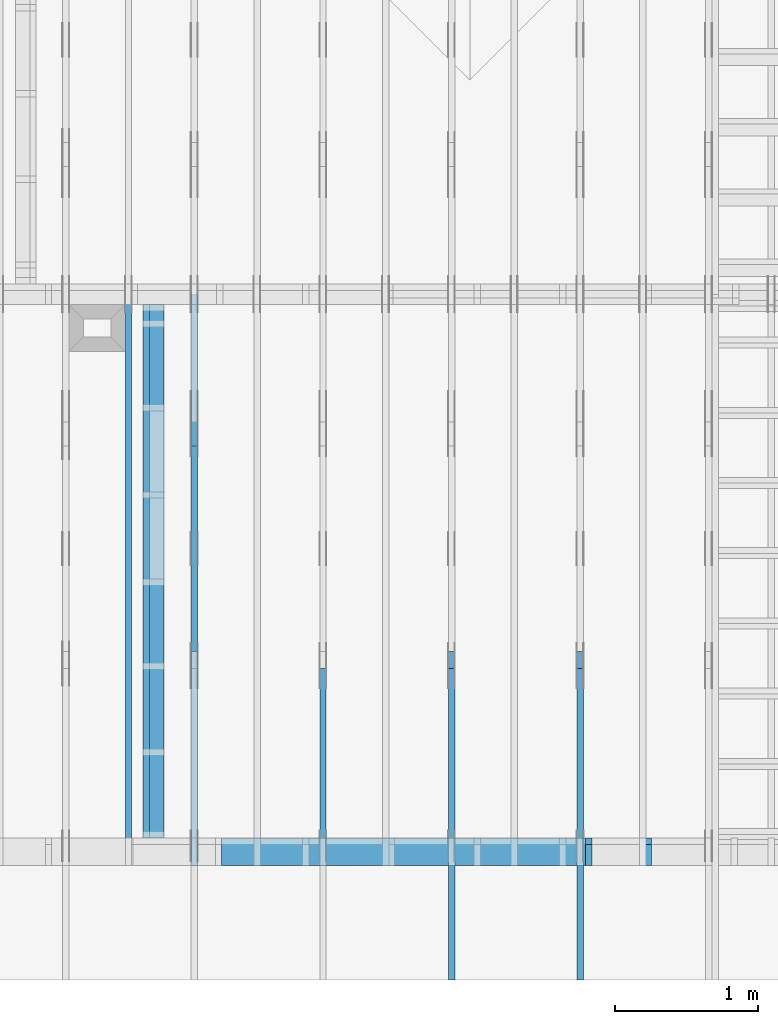
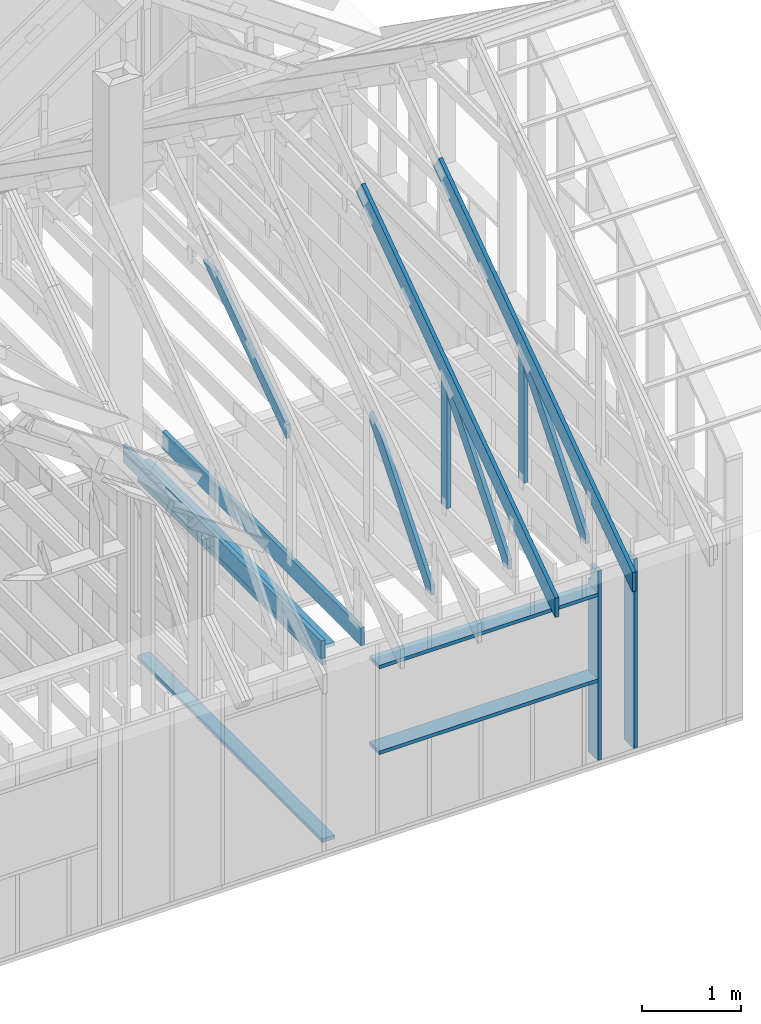
# One storey, part 20 of 70: 17 members, 7 elements without a shape of their own.
"""IFC2X3 building model written with IfcOpenShell, lengths in millimetres."""

from ifc_helpers import new_model, si_unit, frame, origin, origin_with_axes, origin_2d, place, context, project, spatial, faceted_brep, element, aggregate, save


model = new_model("IFC2X3")

# Units and contexts
model_context = context("Model", 3, precision=1e-05, world=origin())
plan_context = context("Plan", 2, precision=1e-05, world=origin_2d())
ifc_project = project(units=[si_unit("LENGTHUNIT", "METRE", prefix="MILLI"), si_unit("AREAUNIT", "SQUARE_METRE"), si_unit("VOLUMEUNIT", "CUBIC_METRE"), si_unit("SOLIDANGLEUNIT", "STERADIAN"), si_unit("PLANEANGLEUNIT", "RADIAN"), si_unit("MASSUNIT", "GRAM"), si_unit("TIMEUNIT", "SECOND"), si_unit("THERMODYNAMICTEMPERATUREUNIT", "DEGREE_CELSIUS"), si_unit("LUMINOUSINTENSITYUNIT", "LUMEN")], contexts=[model_context, plan_context])

# Site, building, storey
site_placement = place(None, origin_with_axes())
site = spatial("IfcSite", under=ifc_project, at=site_placement, CompositionType="ELEMENT")
building_placement = place(site_placement, origin_with_axes())
building = spatial("IfcBuilding", under=site, at=building_placement, Name="Layout 1", CompositionType="ELEMENT")
storey_placement = place(building_placement, origin_with_axes())
storey = spatial("IfcBuildingStorey", under=building, at=storey_placement, Name="Storey 1", CompositionType="ELEMENT", Elevation=0.0)

# Assembly, members
assembly_1_placement = place(storey_placement, frame((-48.55339059325575, 0.0, -2470.0), z_axis=(0.0, -1.0, 6.123031769111886e-17), x_axis=(1.0, 0.0, 0.0)))
assembly_1 = element("IfcElementAssembly", 1, at=assembly_1_placement, inside=storey, Name="VE4", AssemblyPlace="FACTORY", PredefinedType="NOTDEFINED")
member_1_placement = place(assembly_1_placement, frame((10777.499999992955, 2425.0, -195.00000000000003), z_axis=(0.0, 0.0, 1.0), x_axis=(7.044874666267686e-16, -1.0, 0.0)))
member_1 = element("IfcMember", 2, at=member_1_placement, Name="S11", context=model_context, shape_type="Brep", body=[
    faceted_brep([(0.0, 45.00000000000182, 45.00000000000003), (195.00000000186265, 45.00000000000182, 45.00000000000005), (195.00000000186265, 1.8189894035458565e-12, 45.00000000000005), (0.0, 1.8189894035458565e-12, 45.00000000000003), (195.00000000186265, 1.8189894035458565e-12, 2.842170943040401e-14), (195.00000000186265, 1.8189894035458565e-12, 45.00000000000003), (195.00000000186265, 45.00000000000182, 45.00000000000003), (195.00000000186265, 45.00000000000182, 2.842170943040401e-14), (2.7553642961005733e-15, 1.8189894035458565e-12, 45.00000000000003), (1.1939911949768402e-14, 1.8189894035458565e-12, 195.00000000000003), (1.74506405419691e-14, 45.00000000000182, 195.00000000000003), (8.26609288830127e-15, 45.00000000000182, 45.00000000000003), (2335.0, 1.3900710281195688e-12, 2.842170943040403e-14), (2335.0, 1.402010940069337e-12, 195.00000000000003), (2.1932538056648764e-30, 1.8309293154956247e-12, 195.00000000000003), (5.061354936149717e-31, 1.821744767841957e-12, 45.00000000000003), (195.00000000186265, 1.7859250319923102e-12, 45.00000000000003), (195.00000000186265, 1.7831696676962098e-12, 2.842170943040401e-14), (-1.6871183120499057e-31, 45.00000000000182, 45.00000000000003), (-7.310846018882921e-31, 45.000000000001805, 195.00000000000003), (2335.0, 45.00000000000166, 195.00000000000003), (2335.0, 45.00000000000168, 2.8421709430403998e-14), (195.00000000186265, 45.000000000001805, 2.8421709430404004e-14), (195.00000000186265, 45.000000000001805, 45.00000000000003), (2335.0, 45.0, 0.0), (2335.0, 45.0, 195.00000000000003), (2335.0, 0.0, 195.00000000000003), (2335.0, 0.0, 0.0), (2335.0, 45.0, 195.00000000000003), (0.0, 45.0, 195.00000000000003), (0.0, 1.8189894035458565e-12, 195.00000000000003), (2335.0, 1.8189894035458565e-12, 195.00000000000003), (195.00000000186265, 45.00000000000182, 5.2301533330168465e-14), (2335.0, 45.00000000000182, 3.143672930479291e-13), (2335.0, 0.0, 3.143672930479291e-13), (195.00000000186265, 0.0, 5.2301533330168465e-14)], [[[0, 1, 2, 3]], [[4, 5, 6, 7]], [[8, 9, 10, 11]], [[12, 13, 14, 15, 16, 17]], [[18, 19, 20, 21, 22, 23]], [[24, 25, 26, 27]], [[28, 29, 30, 31]], [[32, 33, 34, 35]]]),
])
member_2_placement = place(assembly_1_placement, frame((10358.553390595087, 2425.0, -195.00000000000003), z_axis=(0.0, 0.0, 1.0), x_axis=(-1.836909530733566e-16, -1.0, 0.0)))
member_2 = element("IfcMember", 3, at=member_2_placement, Name="S11", context=model_context, shape_type="Brep", body=[
    faceted_brep([(0.0, 45.00000000001455, 45.00000000000003), (195.00000000186265, 45.00000000001455, 45.00000000000005), (195.00000000186265, 0.0, 45.00000000000005), (0.0, 0.0, 45.00000000000003), (195.00000000186265, -2.1311460639909362e-46, 2.842170943040401e-14), (195.00000000186265, -3.3742366240998114e-31, 45.00000000000003), (195.00000000186265, 45.00000000001273, 45.00000000000003), (195.00000000186265, 45.00000000001273, 2.842170943040401e-14), (2.7553642961003504e-15, -3.3742366240998114e-31, 45.00000000000003), (1.1939911949768181e-14, -1.4621692037765844e-30, 195.00000000000006), (1.7450640541970662e-14, 45.00000000001455, 195.00000000000006), (8.26609288830283e-15, 45.00000000001455, 45.00000000000003), (2335.0, -4.2891837542628763e-13, 2.842170943040403e-14), (2335.0, -4.1697846347651946e-13, 195.00000000000003), (2.1932538056648764e-30, 1.193991194976818e-14, 195.00000000000003), (5.061354936149717e-31, 2.7553642961003504e-15, 45.00000000000003), (195.00000000186265, -3.306437155354634e-14, 45.00000000000003), (195.00000000186265, -3.5819735849646686e-14, 2.842170943040401e-14), (-1.6871183120499057e-31, 45.00000000001273, 45.00000000000003), (-7.310846018882921e-31, 45.00000000001272, 195.00000000000003), (2335.0, 45.00000000001258, 195.00000000000003), (2335.0, 45.00000000001259, 2.8421709430403998e-14), (195.00000000186265, 45.00000000001272, 2.842170943040401e-14), (195.00000000186265, 45.00000000001272, 45.00000000000003), (2335.0, 45.0, 0.0), (2335.0, 45.0, 195.00000000000003), (2335.0, 0.0, 195.00000000000003), (2335.0, 0.0, 0.0), (2335.0, 45.0, 195.00000000000003), (0.0, 45.0, 195.00000000000003), (0.0, 0.0, 195.00000000000003), (2335.0, 0.0, 195.00000000000003), (195.00000000186265, 45.00000000001273, 5.2301533330168465e-14), (2335.0, 45.00000000001273, 3.143672930479291e-13), (2335.0, 0.0, 3.143672930479291e-13), (195.00000000186265, 0.0, 5.2301533330168465e-14)], [[[0, 1, 2, 3]], [[4, 5, 6, 7]], [[8, 9, 10, 11]], [[12, 13, 14, 15, 16, 17]], [[18, 19, 20, 21, 22, 23]], [[24, 25, 26, 27]], [[28, 29, 30, 31]], [[32, 33, 34, 35]]]),
])
member_3_placement = place(assembly_1_placement, frame((10358.553390593253, 2154.9999999987776, -195.0), z_axis=(0.0, 0.0, 1.0), x_axis=(-1.0, 1.2246063538223773e-16, 0.0)))
member_3 = element("IfcMember", 4, at=member_3_placement, Name="S10", context=model_context, shape_type="Brep", body=[
    faceted_brep([(2546.0533905914344, 45.00000000001501, 195.0), (0.0, 45.00000000001501, 195.0), (0.0, 0.0, 195.0), (2546.0533905914344, 0.0, 195.0), (0.0, 45.00000000001501, 0.0), (2546.0533905914344, 45.00000000001501, 3.1179131592892776e-13), (2546.0533905914344, 0.0, 3.1179131592892776e-13), (0.0, 0.0, 0.0), (0.0, 0.0, 0.0), (1.1939911949768178e-14, -1.462169203776584e-30, 195.0), (1.745064054197066e-14, 45.00000000001455, 195.0), (5.51072859220248e-15, 45.00000000001455, -3.3742366241009005e-31), (2546.0533905914344, -4.676869738933916e-13, 5.648094675546328e-29), (2546.0533905914344, -4.557470619436235e-13, 195.0), (2.193253805664876e-30, 1.1939911949768178e-14, 195.0), (0.0, 0.0, 0.0), (2546.0533905914344, 45.00000000001501, 0.0), (2546.0533905914344, 45.00000000001501, 195.0), (2546.0533905914344, 4.547473508864641e-13, 195.0), (2546.0533905914344, 4.547473508864641e-13, 0.0), (0.0, 45.00000000001455, 0.0), (1.5777218104420236e-30, 45.00000000001454, 195.0), (2546.0533905914344, 45.00000000001495, 195.0), (2546.0533905914344, 45.000000000014964, -2.7610131682735413e-30)], [[[0, 1, 2, 3]], [[4, 5, 6, 7]], [[8, 9, 10, 11]], [[12, 13, 14, 15]], [[16, 17, 18, 19]], [[20, 21, 22, 23]]]),
])
member_4_placement = place(assembly_1_placement, frame((7812.500000001819, 1055.0, -195.0), z_axis=(0.0, 0.0, 1.0), x_axis=(1.0, 0.0, 0.0)))
member_4 = element("IfcMember", 5, at=member_4_placement, Name="S10", context=model_context, shape_type="Brep", body=[
    faceted_brep([(2546.0533905914344, 45.0, 195.0), (0.0, 45.0, 195.0), (0.0, 0.0, 195.0), (2546.0533905914344, 0.0, 195.0), (0.0, 45.0, 0.0), (2546.0533905914344, 45.0, 3.1179131592892776e-13), (2546.0533905914344, 0.0, 3.1179131592892776e-13), (0.0, 0.0, 0.0), (0.0, 0.0, 0.0), (1.1939911949768178e-14, -1.462169203776584e-30, 195.0), (1.7450640541968876e-14, 45.0, 195.0), (5.510728592200698e-15, 45.0, -3.3742366240998092e-31), (2546.0533905914344, -4.676869738933916e-13, 2.8636621991490384e-29), (2546.0533905914344, -4.557470619436235e-13, 195.0), (2.193253805664876e-30, 1.1939911949768178e-14, 195.0), (0.0, 0.0, 0.0), (2546.0533905914344, 45.0, 0.0), (2546.0533905914344, 45.0, 195.0), (2546.0533905914344, 0.0, 195.0), (2546.0533905914344, 0.0, 0.0), (0.0, 45.0, 0.0), (-7.31084601888292e-31, 44.999999999999986, 195.0), (2546.0533905914344, 44.99999999999983, 195.0), (2546.0533905914344, 44.999999999999844, -9.466330862652142e-30)], [[[0, 1, 2, 3]], [[4, 5, 6, 7]], [[8, 9, 10, 11]], [[12, 13, 14, 15]], [[16, 17, 18, 19]], [[20, 21, 22, 23]]]),
])
aggregate(assembly_1, [member_1, member_2, member_3, member_4])

# Assembly, member
assembly_2_placement = place(storey_placement, frame((7088.750000000147, 8000.0, 1.3776821480501744e-15), z_axis=(-1.0, 1.836909530733566e-16, 6.123031769111886e-17), x_axis=(-1.836909530733566e-16, -1.0, 0.0)))
assembly_2 = element("IfcElementAssembly", 6, at=assembly_2_placement, inside=storey, Name="MB1", AssemblyPlace="FACTORY", PredefinedType="TRUSS")
member_5_placement = place(assembly_2_placement, frame((8000.000000000001, 220.0, -45.0), z_axis=(0.0, 0.0, 1.0), x_axis=(-1.0, 1.2246063538223773e-16, 0.0)))
member_5 = element("IfcMember", 7, at=member_5_placement, Name="B3", context=model_context, shape_type="Brep", body=[
    faceted_brep([(4000.0000000000005, 220.0000000000005, 45.0), (0.0, 220.0000000000005, 45.0), (0.0, 0.0, 45.0), (4000.0000000000005, 0.0, 45.0), (0.0, 220.0000000000005, 0.0), (4000.0000000000005, 220.0000000000005, 4.89842541528951e-13), (4000.0000000000005, 0.0, 4.89842541528951e-13), (0.0, 0.0, 0.0), (0.0, 0.0, 0.0), (2.755364296100349e-15, -3.3742366240998092e-31, 45.0), (2.969670408019265e-14, 220.0, 45.0), (2.69413397840923e-14, 220.0, -1.6496267940043512e-30), (4000.0000000000005, -7.347638122934265e-13, 7.631468701413364e-29), (4000.0000000000005, -7.320084479973261e-13, 45.0), (5.061354936149714e-31, 2.755364296100349e-15, 45.0), (0.0, 0.0, 0.0), (4000.0000000000005, 220.0000000000005, 0.0), (4000.0000000000005, 220.0000000000005, 45.0), (4000.0000000000005, 5.115907697472721e-13, 45.0), (4000.0000000000005, 5.115907697472721e-13, 0.0), (0.0, 220.0, 0.0), (0.0, 220.0, 45.0), (4000.0000000000005, 220.00000000000065, 45.0), (4000.0000000000005, 220.00000000000065, 7.888609052210118e-30)], [[[0, 1, 2, 3]], [[4, 5, 6, 7]], [[8, 9, 10, 11]], [[12, 13, 14, 15]], [[16, 17, 18, 19]], [[20, 21, 22, 23]]]),
])
aggregate(assembly_2, [member_5])

# Assembly, members
assembly_3_placement = place(storey_placement, frame((10250.0, 8000.0, -9.081170196248781e-13), z_axis=(-1.0, 1.836909530733566e-16, 6.123031769111886e-17), x_axis=(-1.836909530733566e-16, -1.0, 0.0)))
assembly_3 = element("IfcElementAssembly", 8, at=assembly_3_placement, inside=storey, Name="T3", AssemblyPlace="FACTORY", PredefinedType="TRUSS")
member_6_placement = place(assembly_3_placement, frame((4782.309641269037, 3015.0000000009313, -45.00000000000001), z_axis=(0.0, 0.0, 1.0), x_axis=(0.8191520442889916, -0.5735764363510465, 0.0)))
member_6 = element("IfcMember", 9, at=member_6_placement, Name="T8", context=model_context, shape_type="Brep", body=[
    faceted_brep([(4768.153825500145, 194.99999999946158, 45.0), (1.6370904631912708e-10, 194.99999999946158, 45.0), (0.0, 0.0, 45.0), (4904.694295450095, 0.0, 45.0), (1.6370904631912708e-10, 194.99999999946158, 2.004791383006049e-26), (4768.153825500145, 194.99999999946158, 5.839111470709952e-13), (4904.694295450095, 0.0, 6.006319797764554e-13), (0.0, 0.0, 0.0), (2.5849394142282115e-26, -2.1699301500556333e-38, -1.582766615454881e-42), (2.7553642961261982e-15, -2.3129934990511945e-27, 45.0), (1.6369571347777126e-10, 194.99999999920783, 45.0), (1.6369295811347516e-10, 194.99999999920783, 9.850859431479521e-31), (4904.694295450095, 8.093603669211209e-10, 5.505686690999094e-30), (4904.694295450095, 8.09363122285417e-10, 45.0), (-4.546833142611764e-28, 2.755364296100349e-15, 45.0), (0.0, 0.0, 0.0), (4768.153825500146, 194.99999999946203, 5.048709793414476e-29), (4768.153825500146, 194.99999999946203, 45.0), (4904.6942954500955, 8.094502845779061e-10, 45.0), (4904.6942954500955, 8.094502845779061e-10, 5.048709793414476e-29), (1.6370904631912708e-10, 194.99999999920783, 0.0), (1.6370904631912708e-10, 194.99999999920783, 45.0), (4768.153825500145, 194.99999999946164, 45.0), (4768.153825500145, 194.99999999946164, 3.1554436208840472e-30)], [[[0, 1, 2, 3]], [[4, 5, 6, 7]], [[8, 9, 10, 11]], [[12, 13, 14, 15]], [[16, 17, 18, 19]], [[20, 21, 22, 23]]]),
])
member_7_placement = place(assembly_3_placement, frame((6619.999999999389, 220.0, -45.0), z_axis=(0.0, 0.0, 1.0), x_axis=(6.123031769111886e-17, 1.0, 0.0)))
member_7 = element("IfcMember", 10, at=member_7_placement, Name="R1", context=model_context, shape_type="Brep", body=[
    faceted_brep([(1592.2602625068248, 120.0, 45.0), (0.0, 120.0, 45.0), (0.0, 1.4551915228366852e-11, 45.0), (1508.235357921585, 1.4551915228366852e-11, 45.0), (0.0, 120.0, 0.0), (1592.2602625068248, 120.0, 1.949892034404744e-13), (1508.235357921585, 1.4551915228366852e-11, 1.8469946023703405e-13), (0.0, 1.4551915228366852e-11, 0.0), (1.7820367848942657e-27, 1.4551915228366852e-11, -1.0911467847633593e-43), (2.755364296102131e-15, 1.4551915228366852e-11, 45.0), (1.7450640541968876e-14, 120.0, 45.0), (1.4695276245868527e-14, 120.0, -8.997964330932825e-31), (1508.235357921585, -4.605370260698061e-13, 2.81988284147774e-29), (1508.235357921585, -4.577816617737058e-13, 45.0), (2.7425941661909085e-29, 1.4554670592662952e-11, 45.0), (0.0, 1.4551915228366852e-11, 0.0), (1592.260262506825, 120.00000000000011, 1.262177448353619e-29), (1592.260262506825, 120.00000000000011, 45.0), (1508.2353579215853, 0.0, 45.0), (1508.2353579215853, 0.0, 1.262177448353619e-29), (0.0, 120.0, 0.0), (-1.6871183120499046e-31, 120.0, 45.0), (1592.2602625068248, 119.9999999999999, 45.0), (1592.2602625068248, 119.9999999999999, -6.310887241768095e-30)], [[[0, 1, 2, 3]], [[4, 5, 6, 7]], [[8, 9, 10, 11]], [[12, 13, 14, 15]], [[16, 17, 18, 19]], [[20, 21, 22, 23]]]),
])
member_8_placement = place(assembly_3_placement, frame((6563.906131861293, 1682.303582892756, -45.0), z_axis=(0.0, 0.0, 1.0), x_axis=(0.6335417245359889, -0.7737085260432156, 0.0)))
member_8 = element("IfcMember", 11, at=member_8_placement, Name="W6", context=model_context, shape_type="Brep", body=[
    faceted_brep([(1860.8184531590368, 145.00000000000182, 45.0), (258.1329393113165, 145.00000000000182, 45.0), (0.0, 72.4999999999518, 45.0), (88.54013234752438, 0.0, 45.0), (1889.9928508879848, 0.0, 45.0), (1949.3585855061046, 72.4999999999518, 45.0), (258.1329393113165, 145.00000000000182, 3.161112376114843e-14), (1860.8184531590368, 145.00000000000182, 2.2787701010484843e-13), (1949.3585855061046, 72.4999999999518, 2.3871969096889775e-13), (1889.9928508879848, 0.0, 2.314497253876295e-13), (88.54013234752438, 0.0, 1.0842680864105255e-14), (0.0, 72.4999999999518, 0.0), (3.552713678800501e-15, 72.49999999995178, -7.284513455813184e-31), (3.552713678800501e-15, 72.49999999995178, 45.0), (258.13293931131653, 144.9999999999991, 45.0), (258.13293931131653, 144.9999999999991, 8.866211437223917e-31), (88.54013234752439, 0.0, 8.758115402030107e-47), (88.54013234752439, 0.0, 45.0), (0.0, 72.49999999995181, 45.0), (0.0, 72.4999999999518, 8.758115402030107e-47), (1889.9928508879848, 1.2420742274003826e-12, 3.532469951621517e-29), (1889.9928508879848, 1.244829591696483e-12, 45.0), (88.54013234752438, -2.4271270235991317e-14, 45.0), (88.54013234752438, -2.7026634532091666e-14, 1.654849418521736e-30), (1949.3585855061053, 72.49999999999955, 6.310887241768094e-29), (1949.3585855061053, 72.49999999999955, 45.0), (1889.9928508879855, 1.3642420526593924e-12, 45.0), (1889.9928508879855, 1.3642420526593924e-12, 6.310887241768094e-29), (1860.8184531590368, 145.00000000000182, 0.0), (1860.8184531590368, 145.00000000000182, 45.0), (1949.3585855061046, 72.5, 45.0), (1949.3585855061046, 72.5, 0.0), (258.1329393113165, 144.99999999999912, 0.0), (258.1329393113165, 144.9999999999991, 45.0), (1860.8184531590368, 145.00000000000185, 45.0), (1860.8184531590368, 145.00000000000185, 1.5777218104420236e-30)], [[[0, 1, 2, 3, 4, 5]], [[6, 7, 8, 9, 10, 11]], [[12, 13, 14, 15]], [[16, 17, 18, 19]], [[20, 21, 22, 23]], [[24, 25, 26, 27]], [[28, 29, 30, 31]], [[32, 33, 34, 35]]]),
])
aggregate(assembly_3, [member_6, member_7, member_8])

assembly_4_placement = place(storey_placement, frame((9350.0, 8000.0, -9.081170196248781e-13), z_axis=(-1.0, 1.836909530733566e-16, 6.123031769111886e-17), x_axis=(-1.836909530733566e-16, -1.0, 0.0)))
assembly_4 = element("IfcElementAssembly", 12, at=assembly_4_placement, inside=storey, Name="T3", AssemblyPlace="FACTORY", PredefinedType="TRUSS")
member_9_placement = place(assembly_4_placement, frame((4782.309641269037, 3015.0000000009313, -45.00000000000001), z_axis=(0.0, 0.0, 1.0), x_axis=(0.8191520442889916, -0.5735764363510465, 0.0)))
member_9 = element("IfcMember", 13, at=member_9_placement, Name="T8", context=model_context, shape_type="Brep", body=[
    faceted_brep([(4768.153825500145, 194.99999999946158, 45.0), (1.6370904631912708e-10, 194.99999999946158, 45.0), (0.0, 0.0, 45.0), (4904.694295450095, 0.0, 45.0), (1.6370904631912708e-10, 194.99999999946158, 2.004791383006049e-26), (4768.153825500145, 194.99999999946158, 5.839111470709952e-13), (4904.694295450095, 0.0, 6.006319797764554e-13), (0.0, 0.0, 0.0), (2.5849394142282115e-26, -2.1699301500556333e-38, -1.582766615454881e-42), (2.7553642961261982e-15, -2.3129934990511945e-27, 45.0), (1.6369571347777126e-10, 194.99999999920783, 45.0), (1.6369295811347516e-10, 194.99999999920783, 9.850859431479521e-31), (4904.694295450095, 8.093603669211209e-10, 5.505686690999094e-30), (4904.694295450095, 8.09363122285417e-10, 45.0), (-4.546833142611764e-28, 2.755364296100349e-15, 45.0), (0.0, 0.0, 0.0), (4768.153825500146, 194.99999999946203, 5.048709793414476e-29), (4768.153825500146, 194.99999999946203, 45.0), (4904.6942954500955, 8.094502845779061e-10, 45.0), (4904.6942954500955, 8.094502845779061e-10, 5.048709793414476e-29), (1.6370904631912708e-10, 194.99999999920783, 0.0), (1.6370904631912708e-10, 194.99999999920783, 45.0), (4768.153825500145, 194.99999999946164, 45.0), (4768.153825500145, 194.99999999946164, 3.1554436208840472e-30)], [[[0, 1, 2, 3]], [[4, 5, 6, 7]], [[8, 9, 10, 11]], [[12, 13, 14, 15]], [[16, 17, 18, 19]], [[20, 21, 22, 23]]]),
])
member_10_placement = place(assembly_4_placement, frame((6619.999999999389, 220.0, -45.0), z_axis=(0.0, 0.0, 1.0), x_axis=(6.123031769111886e-17, 1.0, 0.0)))
member_10 = element("IfcMember", 14, at=member_10_placement, Name="R1", context=model_context, shape_type="Brep", body=[
    faceted_brep([(1592.2602625068248, 120.0, 45.0), (0.0, 120.0, 45.0), (0.0, 1.4551915228366852e-11, 45.0), (1508.235357921585, 1.4551915228366852e-11, 45.0), (0.0, 120.0, 0.0), (1592.2602625068248, 120.0, 1.949892034404744e-13), (1508.235357921585, 1.4551915228366852e-11, 1.8469946023703405e-13), (0.0, 1.4551915228366852e-11, 0.0), (1.7820367848942657e-27, 1.4551915228366852e-11, -1.0911467847633593e-43), (2.755364296102131e-15, 1.4551915228366852e-11, 45.0), (1.7450640541968876e-14, 120.0, 45.0), (1.4695276245868527e-14, 120.0, -8.997964330932825e-31), (1508.235357921585, -4.605370260698061e-13, 2.81988284147774e-29), (1508.235357921585, -4.577816617737058e-13, 45.0), (2.7425941661909085e-29, 1.4554670592662952e-11, 45.0), (0.0, 1.4551915228366852e-11, 0.0), (1592.260262506825, 120.00000000000011, 1.262177448353619e-29), (1592.260262506825, 120.00000000000011, 45.0), (1508.2353579215853, 0.0, 45.0), (1508.2353579215853, 0.0, 1.262177448353619e-29), (0.0, 120.0, 0.0), (-1.6871183120499046e-31, 120.0, 45.0), (1592.2602625068248, 119.9999999999999, 45.0), (1592.2602625068248, 119.9999999999999, -6.310887241768095e-30)], [[[0, 1, 2, 3]], [[4, 5, 6, 7]], [[8, 9, 10, 11]], [[12, 13, 14, 15]], [[16, 17, 18, 19]], [[20, 21, 22, 23]]]),
])
member_11_placement = place(assembly_4_placement, frame((6563.906131861293, 1682.303582892756, -45.0), z_axis=(0.0, 0.0, 1.0), x_axis=(0.6335417245359889, -0.7737085260432156, 0.0)))
member_11 = element("IfcMember", 15, at=member_11_placement, Name="W6", context=model_context, shape_type="Brep", body=[
    faceted_brep([(1860.8184531590368, 145.00000000000182, 45.0), (258.1329393113165, 145.00000000000182, 45.0), (0.0, 72.4999999999518, 45.0), (88.54013234752438, 0.0, 45.0), (1889.9928508879848, 0.0, 45.0), (1949.3585855061046, 72.4999999999518, 45.0), (258.1329393113165, 145.00000000000182, 3.161112376114843e-14), (1860.8184531590368, 145.00000000000182, 2.2787701010484843e-13), (1949.3585855061046, 72.4999999999518, 2.3871969096889775e-13), (1889.9928508879848, 0.0, 2.314497253876295e-13), (88.54013234752438, 0.0, 1.0842680864105255e-14), (0.0, 72.4999999999518, 0.0), (3.552713678800501e-15, 72.49999999995178, -7.284513455813184e-31), (3.552713678800501e-15, 72.49999999995178, 45.0), (258.13293931131653, 144.9999999999991, 45.0), (258.13293931131653, 144.9999999999991, 8.866211437223917e-31), (88.54013234752439, 0.0, 8.758115402030107e-47), (88.54013234752439, 0.0, 45.0), (0.0, 72.49999999995181, 45.0), (0.0, 72.4999999999518, 8.758115402030107e-47), (1889.9928508879848, 1.2420742274003826e-12, 3.532469951621517e-29), (1889.9928508879848, 1.244829591696483e-12, 45.0), (88.54013234752438, -2.4271270235991317e-14, 45.0), (88.54013234752438, -2.7026634532091666e-14, 1.654849418521736e-30), (1949.3585855061053, 72.49999999999955, 6.310887241768094e-29), (1949.3585855061053, 72.49999999999955, 45.0), (1889.9928508879855, 1.3642420526593924e-12, 45.0), (1889.9928508879855, 1.3642420526593924e-12, 6.310887241768094e-29), (1860.8184531590368, 145.00000000000182, 0.0), (1860.8184531590368, 145.00000000000182, 45.0), (1949.3585855061046, 72.5, 45.0), (1949.3585855061046, 72.5, 0.0), (258.1329393113165, 144.99999999999912, 0.0), (258.1329393113165, 144.9999999999991, 45.0), (1860.8184531590368, 145.00000000000185, 45.0), (1860.8184531590368, 145.00000000000185, 1.5777218104420236e-30)], [[[0, 1, 2, 3, 4, 5]], [[6, 7, 8, 9, 10, 11]], [[12, 13, 14, 15]], [[16, 17, 18, 19]], [[20, 21, 22, 23]], [[24, 25, 26, 27]], [[28, 29, 30, 31]], [[32, 33, 34, 35]]]),
])
aggregate(assembly_4, [member_9, member_10, member_11])

# Assembly, member
assembly_5_placement = place(storey_placement, frame((8450.0, 8000.0, -9.081170196248781e-13), z_axis=(-1.0, 1.836909530733566e-16, 6.123031769111886e-17), x_axis=(-1.836909530733566e-16, -1.0, 0.0)))
assembly_5 = element("IfcElementAssembly", 16, at=assembly_5_placement, inside=storey, Name="T3", AssemblyPlace="FACTORY", PredefinedType="TRUSS")
member_12_placement = place(assembly_5_placement, frame((6563.906131861293, 1682.303582892756, -45.0), z_axis=(0.0, 0.0, 1.0), x_axis=(0.6335417245359889, -0.7737085260432156, 0.0)))
member_12 = element("IfcMember", 17, at=member_12_placement, Name="W6", context=model_context, shape_type="Brep", body=[
    faceted_brep([(1860.8184531590368, 145.00000000000182, 45.0), (258.1329393113165, 145.00000000000182, 45.0), (0.0, 72.4999999999518, 45.0), (88.54013234752438, 0.0, 45.0), (1889.9928508879848, 0.0, 45.0), (1949.3585855061046, 72.4999999999518, 45.0), (258.1329393113165, 145.00000000000182, 3.161112376114843e-14), (1860.8184531590368, 145.00000000000182, 2.2787701010484843e-13), (1949.3585855061046, 72.4999999999518, 2.3871969096889775e-13), (1889.9928508879848, 0.0, 2.314497253876295e-13), (88.54013234752438, 0.0, 1.0842680864105255e-14), (0.0, 72.4999999999518, 0.0), (3.552713678800501e-15, 72.49999999995178, -7.284513455813184e-31), (3.552713678800501e-15, 72.49999999995178, 45.0), (258.13293931131653, 144.9999999999991, 45.0), (258.13293931131653, 144.9999999999991, 8.866211437223917e-31), (88.54013234752439, 0.0, 8.758115402030107e-47), (88.54013234752439, 0.0, 45.0), (0.0, 72.49999999995181, 45.0), (0.0, 72.4999999999518, 8.758115402030107e-47), (1889.9928508879848, 1.2420742274003826e-12, 3.532469951621517e-29), (1889.9928508879848, 1.244829591696483e-12, 45.0), (88.54013234752438, -2.4271270235991317e-14, 45.0), (88.54013234752438, -2.7026634532091666e-14, 1.654849418521736e-30), (1949.3585855061053, 72.49999999999955, 6.310887241768094e-29), (1949.3585855061053, 72.49999999999955, 45.0), (1889.9928508879855, 1.3642420526593924e-12, 45.0), (1889.9928508879855, 1.3642420526593924e-12, 6.310887241768094e-29), (1860.8184531590368, 145.00000000000182, 0.0), (1860.8184531590368, 145.00000000000182, 45.0), (1949.3585855061046, 72.5, 45.0), (1949.3585855061046, 72.5, 0.0), (258.1329393113165, 144.99999999999912, 0.0), (258.1329393113165, 144.9999999999991, 45.0), (1860.8184531590368, 145.00000000000185, 45.0), (1860.8184531590368, 145.00000000000185, 1.5777218104420236e-30)], [[[0, 1, 2, 3, 4, 5]], [[6, 7, 8, 9, 10, 11]], [[12, 13, 14, 15]], [[16, 17, 18, 19]], [[20, 21, 22, 23]], [[24, 25, 26, 27]], [[28, 29, 30, 31]], [[32, 33, 34, 35]]]),
])
aggregate(assembly_5, [member_12])

# Assembly, members
assembly_6_placement = place(storey_placement, frame((7550.000000000001, 8000.0, -9.081170196248781e-13), z_axis=(-1.0, 1.836909530733566e-16, 6.123031769111886e-17), x_axis=(-1.836909530733566e-16, -1.0, 0.0)))
assembly_6 = element("IfcElementAssembly", 18, at=assembly_6_placement, inside=storey, Name="T3", AssemblyPlace="FACTORY", PredefinedType="TRUSS")
member_13_placement = place(assembly_6_placement, frame((7999.999999999999, 220.0, -45.0), z_axis=(0.0, 0.0, 1.0), x_axis=(-1.0, 1.2246063538223773e-16, 0.0)))
member_13 = element("IfcMember", 19, at=member_13_placement, Name="B3", context=model_context, shape_type="Brep", body=[
    faceted_brep([(3999.9999999999995, 220.00000000000048, 45.0), (0.0, 220.00000000000048, 45.0), (0.0, 0.0, 45.0), (3999.9999999999995, 0.0, 45.0), (0.0, 220.00000000000048, 0.0), (3999.9999999999995, 220.00000000000048, 4.898425415289508e-13), (3999.9999999999995, 0.0, 4.898425415289508e-13), (0.0, 0.0, 0.0), (0.0, 0.0, 0.0), (2.755364296100349e-15, -3.3742366240998092e-31, 45.0), (2.969670408019265e-14, 220.0, 45.0), (2.69413397840923e-14, 220.0, -1.6496267940043512e-30), (3999.9999999999995, -7.347638122934263e-13, 7.457441671638533e-29), (3999.9999999999995, -7.320084479973259e-13, 45.0), (5.061354936149714e-31, 2.755364296100349e-15, 45.0), (0.0, 0.0, 0.0), (3999.9999999999995, 220.00000000000048, 0.0), (3999.9999999999995, 220.00000000000048, 45.0), (3999.9999999999995, 4.831690603168681e-13, 45.0), (3999.9999999999995, 4.831690603168681e-13, 0.0), (0.0, 220.0, 0.0), (0.0, 220.0, 45.0), (3999.9999999999995, 220.00000000000065, 45.0), (3999.9999999999995, 220.00000000000065, 9.466330862652142e-30)], [[[0, 1, 2, 3]], [[4, 5, 6, 7]], [[8, 9, 10, 11]], [[12, 13, 14, 15]], [[16, 17, 18, 19]], [[20, 21, 22, 23]]]),
])
member_14_placement = place(assembly_6_placement, frame((6583.168583270521, 1754.024964554012, -44.99999999999999), z_axis=(0.0, 0.0, 1.0), x_axis=(-0.8191520442890866, 0.5735764363509106, 0.0)))
member_14 = element("IfcMember", 20, at=member_14_placement, Name="SC5", context=model_context, shape_type="Brep", body=[
    faceted_brep([(2065.552220741256, 145.00000000323507, 45.0), (0.0, 145.00000000323507, 45.0), (101.53009304067928, 0.0, 45.0), (1858.4707597638994, 0.0, 45.0), (0.0, 145.00000000323507, 0.0), (2065.552220741256, 145.00000000323507, 2.5294883736716636e-13), (1858.4707597638994, 0.0, 2.275895100799972e-13), (101.53009304067928, 0.0, 1.2433439704179296e-14), (101.53009304067926, -1.4210854715202004e-14, 1.2188192559213497e-30), (101.53009304067926, -1.4210854715202004e-14, 45.0), (2.842170943040401e-14, 145.0000000003174, 45.0), (2.842170943040401e-14, 145.0000000003174, -8.457017451291223e-31), (1858.4707597638994, 3.6386987741452655e-09, 1.1604838111769461e-29), (1858.4707597638994, 3.6387015295095616e-09, 45.0), (101.53009304067928, -7.598718304623376e-15, 45.0), (101.53009304067928, -1.0354082600723725e-14, 6.339837670416306e-31), (2065.552220741256, 145.00000000323575, -3.7865323450608567e-29), (2065.552220741256, 145.00000000323575, 45.0), (1858.4707597638994, 3.639456735982094e-09, 45.0), (1858.4707597638994, 3.639456735982094e-09, -3.7865323450608567e-29), (0.0, 145.0000000003174, 0.0), (0.0, 145.0000000003174, 45.0), (2065.552220741256, 145.00000000323564, 45.0), (2065.552220741256, 145.00000000323564, 3.6287601640166543e-29)], [[[0, 1, 2, 3]], [[4, 5, 6, 7]], [[8, 9, 10, 11]], [[12, 13, 14, 15]], [[16, 17, 18, 19]], [[20, 21, 22, 23]]]),
])
aggregate(assembly_6, [member_13, member_14])

assembly_7_placement = place(storey_placement, frame((7359.197265625001, 195.0, -2470.0), z_axis=(1.0, -6.123031769111886e-17, 6.123031769111886e-17), x_axis=(6.123031769111886e-17, 1.0, 0.0)))
assembly_7 = element("IfcElementAssembly", 21, at=assembly_7_placement, inside=storey, Name="VE10", AssemblyPlace="FACTORY", PredefinedType="NOTDEFINED")
member_15_placement = place(assembly_7_placement, frame((1.457281561048629e-13, 2425.0, -145.0), z_axis=(0.0, 0.0, 1.0), x_axis=(1.0, 0.0, 0.0)))
member_15 = element("IfcMember", 22, at=member_15_placement, Name="P15", context=model_context, shape_type="Brep", body=[
    faceted_brep([(3732.500000000001, 45.0, 145.0), (2.755364296100349e-15, 45.0, 145.0), (0.0, 0.0, 145.0), (3732.500000000001, 0.0, 145.0), (2.755364296100349e-15, 45.0, 3.3742366240998092e-31), (3732.500000000001, 45.0, 4.570843215642024e-13), (3732.500000000001, 0.0, 4.570843215642024e-13), (0.0, 0.0, 0.0), (-3.944304526105059e-31, 4.830220384078616e-47, 2.415110192039308e-47), (8.878396065212235e-15, -1.0872540233210496e-30, 145.0), (1.4389124657412933e-14, 45.0, 145.0), (5.510728592200698e-15, 45.0, -1.6871183120499044e-31), (3732.500000000001, -6.856264823463037e-13, 4.198112733150847e-29), (3732.500000000001, -6.767480862810914e-13, 145.0), (1.6308810349815745e-30, 8.878396065212235e-15, 145.0), (0.0, 0.0, 0.0), (3732.500000000001, 45.0, 0.0), (3732.500000000001, 45.0, 145.0), (3732.500000000001, 0.0, 145.0), (3732.500000000001, 0.0, 0.0), (2.755364296100349e-15, 45.0, 0.0), (2.7553642961003484e-15, 44.99999999999999, 145.0), (3732.500000000001, 44.999999999999766, 145.0), (3732.500000000001, 44.99999999999977, -1.3805065841367707e-29)], [[[0, 1, 2, 3]], [[4, 5, 6, 7]], [[8, 9, 10, 11]], [[12, 13, 14, 15]], [[16, 17, 18, 19]], [[20, 21, 22, 23]]]),
])
member_16_placement = place(assembly_7_placement, frame((3732.5000000000005, 90.0, -145.0), z_axis=(0.0, 0.0, 1.0), x_axis=(-1.0, 1.2246063538223773e-16, 0.0)))
member_16 = element("IfcMember", 23, at=member_16_placement, Name="P15", context=model_context, shape_type="Brep", body=[
    faceted_brep([(3732.5000000000005, 45.000000000000455, 145.0), (0.0, 45.000000000000455, 145.0), (0.0, 0.0, 145.0), (3732.5000000000005, 0.0, 145.0), (0.0, 45.000000000000455, 0.0), (3732.5000000000005, 45.000000000000455, 4.570843215642024e-13), (3732.5000000000005, 0.0, 4.570843215642024e-13), (0.0, 0.0, 0.0), (0.0, 0.0, 0.0), (8.878396065212235e-15, -1.0872540233210496e-30, 145.0), (1.4389124657412933e-14, 45.0, 145.0), (5.510728592200698e-15, 45.0, -3.3742366240998092e-31), (3732.5000000000005, -6.856264823463036e-13, 6.982545209548136e-29), (3732.5000000000005, -6.767480862810913e-13, 145.0), (1.6308810349815745e-30, 8.878396065212235e-15, 145.0), (0.0, 0.0, 0.0), (3732.5000000000005, 45.000000000000455, 0.0), (3732.5000000000005, 45.000000000000455, 145.0), (3732.5000000000005, 4.547473508864641e-13, 145.0), (3732.5000000000005, 4.547473508864641e-13, 0.0), (0.0, 45.0, 0.0), (1.5777218104420236e-30, 44.99999999999999, 145.0), (3732.5000000000005, 45.00000000000059, 145.0), (3732.5000000000005, 45.0000000000006, 8.67746995743113e-30)], [[[0, 1, 2, 3]], [[4, 5, 6, 7]], [[8, 9, 10, 11]], [[12, 13, 14, 15]], [[16, 17, 18, 19]], [[20, 21, 22, 23]]]),
])
member_17_placement = place(assembly_7_placement, frame((1.3378824415499132e-13, 2229.9999999981374, -145.0), z_axis=(0.0, 0.0, 1.0), x_axis=(1.0, 0.0, 0.0)))
member_17 = element("IfcMember", 24, at=member_17_placement, Name="L5", context=model_context, shape_type="Brep", body=[
    faceted_brep([(3732.500000000001, 195.00000000186265, 45.0), (1.1939911949871576e-14, 195.00000000186265, 45.0), (0.0, 0.0, 45.0), (3732.500000000001, 0.0, 45.0), (1.1939911949871576e-14, 195.00000000186265, 1.4621692037892461e-30), (3732.500000000001, 195.00000000186265, 4.570843215642024e-13), (3732.500000000001, 0.0, 4.570843215642024e-13), (0.0, 0.0, 0.0), (0.0, 0.0, 0.0), (2.755364296100349e-15, -3.3742366240998092e-31, 45.0), (2.6635188195864806e-14, 195.00000000186265, 45.0), (2.3879823899764457e-14, 195.00000000186265, -7.310846018959277e-31), (3732.500000000001, 1.8624151582779173e-09, 1.4082419120707965e-29), (3732.500000000001, 1.8624179136422134e-09, 45.0), (-1.3748512341955934e-27, 2.755364296100349e-15, 45.0), (0.0, 0.0, 0.0), (3732.500000000001, 195.00000000186265, 0.0), (3732.500000000001, 195.00000000186265, 45.0), (3732.500000000001, 1.862645149230957e-09, 45.0), (3732.500000000001, 1.862645149230957e-09, 0.0), (1.1939911949871576e-14, 195.00000000186265, 0.0), (1.1939911949871576e-14, 195.00000000186265, 45.0), (3732.500000000001, 195.00000000186242, 45.0), (3732.500000000001, 195.00000000186242, -1.4199496293978212e-29)], [[[0, 1, 2, 3]], [[4, 5, 6, 7]], [[8, 9, 10, 11]], [[12, 13, 14, 15]], [[16, 17, 18, 19]], [[20, 21, 22, 23]]]),
])
aggregate(assembly_7, [member_15, member_16, member_17])

save(model, "model.ifc")
